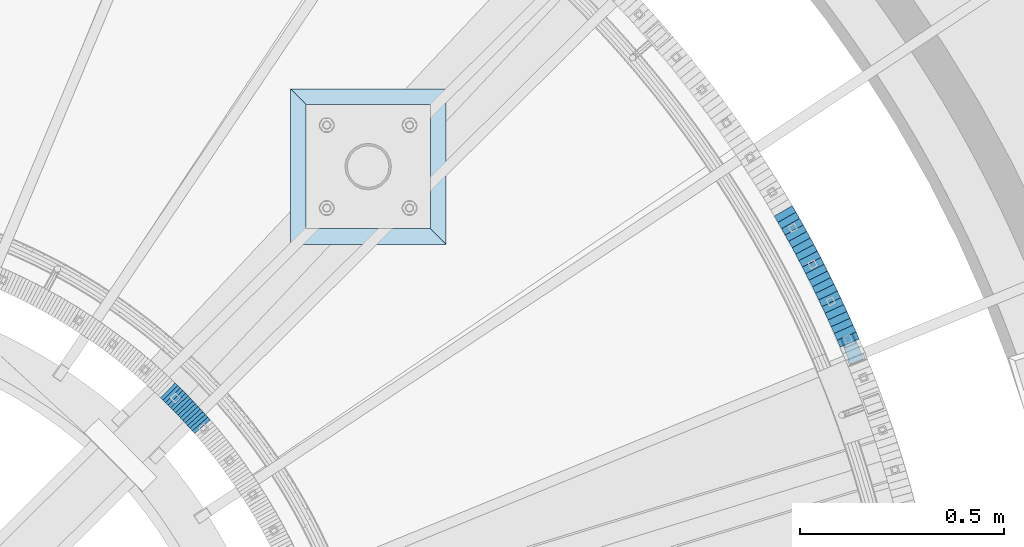
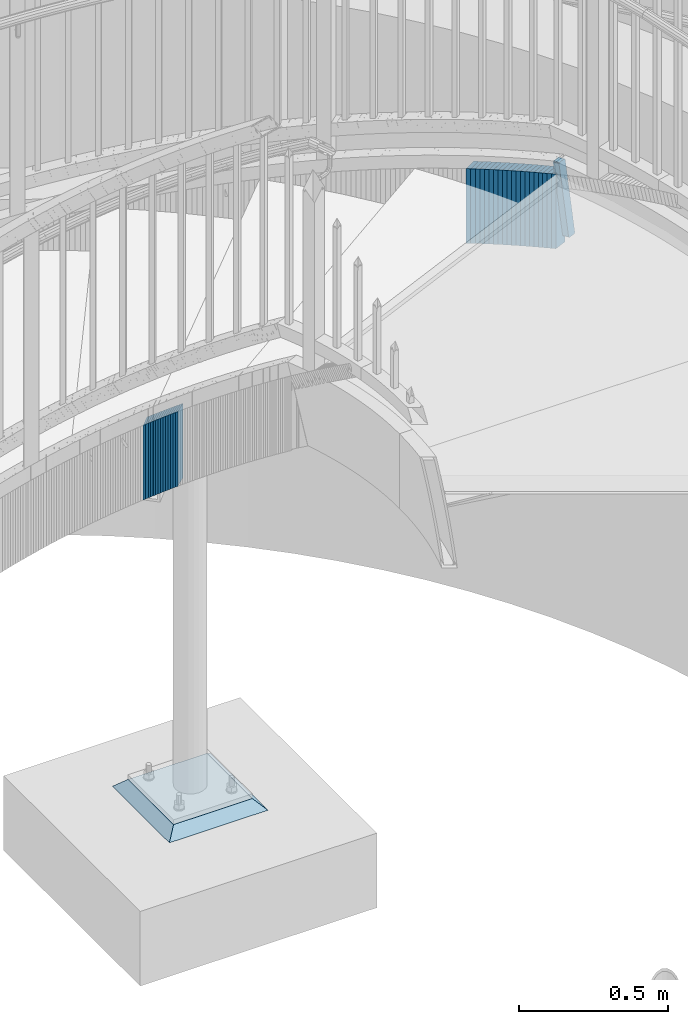
# One storey, part 911 of 975: 36 plates.
"""IFC2X3 building model written with IfcOpenShell, lengths in millimetres."""

from ifc_helpers import new_model, si_unit, frame, origin_with_axes, place, context, subcontext, project, spatial, faceted_brep, material, type_object, element, save


model = new_model("IFC2X3")

# Units and contexts
model_context = context("Model", 3, precision=1e-05, world=origin_with_axes())
body_context = subcontext(model_context, "Body", "Model", "MODEL_VIEW")
ifc_project = project(units=[si_unit("LENGTHUNIT", "METRE", prefix="MILLI"), si_unit("AREAUNIT", "SQUARE_METRE"), si_unit("VOLUMEUNIT", "CUBIC_METRE"), si_unit("MASSUNIT", "GRAM", prefix="KILO"), si_unit("TIMEUNIT", "SECOND"), si_unit("PLANEANGLEUNIT", "RADIAN"), si_unit("SOLIDANGLEUNIT", "STERADIAN"), si_unit("THERMODYNAMICTEMPERATUREUNIT", "DEGREE_CELSIUS"), si_unit("LUMINOUSINTENSITYUNIT", "LUMEN")], contexts=[model_context])

# Site, building, storey
site_placement = place(None, origin_with_axes())
site = spatial("IfcSite", under=ifc_project, at=site_placement, CompositionType="ELEMENT")
building_placement = place(site_placement, origin_with_axes())
building = spatial("IfcBuilding", under=site, at=building_placement, Name="Undefined", CompositionType="ELEMENT")
storey_placement = place(building_placement, origin_with_axes())
storey = spatial("IfcBuildingStorey", under=building, at=storey_placement, Name="Undefined", CompositionType="ELEMENT", Elevation=0.0)

# Plates
ifc_material_1 = material(Name="STEEL/A36")
plate_type_1 = type_object("IfcPlateType", PredefinedType="NOTDEFINED")
plate_1_placement = place(storey_placement, frame((37390.0475456913, 4538.09798117989, 2176.45959824117), z_axis=(0.0568676112012981, -0.132966091969578, -0.98948779334694), x_axis=(-0.920374035033144, -0.391039019014061, -0.000348203000012044)))
element("IfcPlate", 1, at=plate_1_placement, inside=storey, type_object=plate_type_1, material=ifc_material_1, Name="PLATE", context=body_context, shape_type="Brep", body=[
    faceted_brep([(0.0228958955340204, -12.699999999988, 6.3728136888293), (1.02632801964501, -12.6999999999025, 285.666801916679), (1.02632801963773, 12.700000000088, 285.666801916676), (0.0228958955340204, 12.7000000000007, 6.37281368882543), (1.51622114569182, -12.6999999999007, 288.089826975847), (1.51622114568454, 12.7000000000862, 288.089826975844), (2.89423209767847, -12.6999999999007, 290.142174784707), (2.89423209766392, 12.700000000088, 290.142174784703), (4.95151747122145, -12.6999999998989, 291.512803328148), (4.95151747121417, 12.7000000000917, 291.512803328144), (7.376286942359, -12.699999999897, 291.993988037131), (7.376286942359, 12.7000000000935, 291.993988037127), (29.6011096881266, -12.6999999998807, 291.993988037132), (29.6011096881193, 12.7000000001099, 291.993988037128), (32.036417817144, -12.6999999998789, 291.50843807308), (32.036417817144, 12.7000000001135, 291.508438073076), (34.0992964053003, -12.699999999877, 290.126042911988), (34.099296405293, 12.7000000001153, 290.126042911984), (35.4742712354564, -12.699999999877, 288.058211036017), (35.4742712354491, 12.7000000001153, 288.058211036012), (35.9510686101858, -12.6999999998734, 285.621174164258), (35.9510686101785, 12.7000000001135, 285.621174164253), (34.947628390335, -12.6999999999607, 6.32718593645666), (34.9476283903423, 12.7000000000298, 6.32718593645279), (34.4577352117849, -12.6999999999625, 3.90416093395709), (34.4577352117776, 12.700000000028, 3.90416093395277), (33.0797242477929, -12.6999999999625, 1.85181318753632), (33.0797242477856, 12.7000000000262, 1.85181318753177), (31.0224388969073, -12.6999999999662, 0.481184691480735), (31.0224388969073, 12.7000000000226, 0.481184691476415), (28.597669468305, -12.699999999968, 6.46878106635995e-11), (28.5976694682977, 12.7000000000226, 6.08224581810646e-11), (6.37285481827712, -12.699999999988, 1.55750967678614e-11), (6.37285481826984, 12.7000000000062, 1.10276232589968e-11), (3.93754673174408, -12.6999999999898, 0.485549946415972), (3.93754673174408, 12.7000000000044, 0.485549946412107), (1.87466816604865, -12.699999999988, 1.8679450599617), (1.87466816604865, 12.7000000000007, 1.86794505995761), (0.499693323406973, -12.6999999999898, 3.93577687344907), (0.499693323406973, 12.7000000000025, 3.93577687344407)], [[[0, 1, 2, 3]], [[1, 4, 5, 2]], [[4, 6, 7, 5]], [[6, 8, 9, 7]], [[8, 10, 11, 9]], [[10, 12, 13, 11]], [[12, 14, 15, 13]], [[14, 16, 17, 15]], [[16, 18, 19, 17]], [[18, 20, 21, 19]], [[20, 22, 23, 21]], [[22, 24, 25, 23]], [[24, 26, 27, 25]], [[26, 28, 29, 27]], [[28, 30, 31, 29]], [[30, 32, 33, 31]], [[32, 34, 35, 33]], [[34, 36, 37, 35]], [[36, 38, 39, 37]], [[38, 0, 3, 39]], [[5, 7, 9, 11, 13, 15, 17, 19, 21, 23, 25, 27, 29, 31, 33, 35, 37, 39, 3, 2]], [[38, 36, 34, 32, 30, 28, 26, 24, 22, 20, 18, 16, 14, 12, 10, 8, 6, 4, 1, 0]]]),
])
plate_type_2 = type_object("IfcPlateType", PredefinedType="NOTDEFINED")
plate_2_placement = place(storey_placement, frame((37369.2216824325, 4542.73662108243, 2127.79999999174), z_axis=(0.395909297944737, -0.918289620871817, 0.0), x_axis=(0.0, 0.0, -1.0)))
element("IfcPlate", 2, at=plate_2_placement, inside=storey, type_object=plate_type_2, material=ifc_material_1, Name="WALL", context=body_context, shape_type="Brep", body=[
    faceted_brep([(0.0, -25.3999999999724, -1.81898940354586e-11), (-5.80000019073486, -25.4000000000669, 18.1859836578205), (-5.80000019073486, 25.3999999999942, 18.1859836578369), (0.0, 25.3999999999869, 1.45519152283669e-11), (299.0, -25.4000000000669, 18.1859836578205), (299.0, 25.3999999999942, 18.1859836578369), (304.799987792969, -25.3999999999724, -1.81898940354586e-11), (304.799987792969, 25.3999999999869, 1.45519152283669e-11)], [[[0, 1, 2, 3]], [[1, 4, 5, 2]], [[4, 6, 7, 5]], [[6, 0, 3, 7]], [[5, 7, 3, 2]], [[6, 4, 1, 0]]]),
])
plate_3_placement = place(storey_placement, frame((37354.273054634, 4576.27457774003, 2116.09999999174), z_axis=(0.409214678154851, -0.912438133345282, 0.0), x_axis=(0.0, 0.0, -1.0)))
element("IfcPlate", 3, at=plate_3_placement, inside=storey, type_object=plate_type_2, material=ifc_material_1, Name="WALL", context=body_context, shape_type="Brep", body=[
    faceted_brep([(0.0, -25.3999999999724, -1.81898940354586e-11), (-5.80000019073486, -25.4000000000015, 18.0834178924524), (-5.80000019073486, 25.4000000000233, 18.0834178924579), (0.0, 25.3999999999869, 1.45519152283669e-11), (299.0, -25.4000000000015, 18.0834178924524), (299.0, 25.4000000000233, 18.0834178924579), (304.799987792969, -25.3999999999724, -1.81898940354586e-11), (304.799987792969, 25.3999999999869, 1.45519152283669e-11)], [[[0, 1, 2, 3]], [[1, 4, 5, 2]], [[4, 6, 7, 5]], [[6, 0, 3, 7]], [[5, 7, 3, 2]], [[6, 4, 1, 0]]]),
])
plate_4_placement = place(storey_placement, frame((37346.7204345728, 4592.89111969677, 2110.29999999174), z_axis=(0.413802944225842, -0.910366477496851, 0.0), x_axis=(0.0, 0.0, -1.0)))
element("IfcPlate", 4, at=plate_4_placement, inside=storey, type_object=plate_type_2, material=ifc_material_1, Name="WALL", context=body_context, shape_type="Brep", body=[
    faceted_brep([(0.0, -25.3999999999724, -1.81898940354586e-11), (-5.80000019073486, -25.3999999999796, 18.1245689392126), (-5.80000019073486, 25.3999999999651, 18.1245689391963), (0.0, 25.3999999999869, 1.45519152283669e-11), (299.0, -25.3999999999796, 18.1245689392126), (299.0, 25.3999999999651, 18.1245689391963), (304.799987792969, -25.3999999999724, -1.81898940354586e-11), (304.799987792969, 25.3999999999869, 1.45519152283669e-11)], [[[0, 1, 2, 3]], [[1, 4, 5, 2]], [[4, 6, 7, 5]], [[6, 0, 3, 7]], [[5, 7, 3, 2]], [[6, 4, 1, 0]]]),
])
plate_5_placement = place(storey_placement, frame((37339.0674721854, 4609.50686617453, 2104.49999999174), z_axis=(0.418359892189787, -0.908281344412044, 0.0), x_axis=(0.0, 0.0, -1.0)))
element("IfcPlate", 5, at=plate_5_placement, inside=storey, type_object=plate_type_2, material=ifc_material_1, Name="WALL", context=body_context, shape_type="Brep", body=[
    faceted_brep([(0.0, -25.3999999999724, -1.81898940354586e-11), (-5.80000019073486, -25.4000000000087, 18.1661777496374), (-5.80000019073486, 25.3999999999505, 18.1661777496083), (0.0, 25.3999999999869, 1.45519152283669e-11), (299.0, -25.4000000000087, 18.1661777496374), (299.0, 25.3999999999505, 18.1661777496083), (304.799987792969, -25.3999999999724, -1.81898940354586e-11), (304.799987792969, 25.3999999999869, 1.45519152283669e-11)], [[[0, 1, 2, 3]], [[1, 4, 5, 2]], [[4, 6, 7, 5]], [[6, 0, 3, 7]], [[5, 7, 3, 2]], [[6, 4, 1, 0]]]),
])
for number, where, z_axis, x_axis, name in (
    (6, (37331.2635302433, 4626.02968518606, 2098.69999999174), (0.427132294153765, -0.904189141325498, 0.0), (0.0, 0.0, -1.0), "WALL"),
    (7, (37323.5635302596, 4642.32968518814, 2092.89999999174), (0.427132294153765, -0.904189141325498, 0.0), (0.0, 0.0, -1.0), "WALL"),
):
    element("IfcPlate", number, at=place(storey_placement, frame(where, z_axis=z_axis, x_axis=x_axis)), inside=storey, type_object=plate_type_2, material=ifc_material_1, Name=name, context=body_context, shape_type="Brep", body=[
        faceted_brep([(0.0, -25.3999999999724, -1.81898940354586e-11), (-5.80000019073486, -25.4000000000306, 18.0272026061921), (-5.80000019073486, 25.4000000001324, 18.0272026062557), (0.0, 25.3999999999869, 1.45519152283669e-11), (299.0, -25.4000000000306, 18.0272026061921), (299.0, 25.4000000001324, 18.0272026062557), (304.799987792969, -25.3999999999724, -1.81898940354586e-11), (304.799987792969, 25.3999999999869, 1.45519152283669e-11)], [[[0, 1, 2, 3]], [[1, 4, 5, 2]], [[4, 6, 7, 5]], [[6, 0, 3, 7]], [[5, 7, 3, 2]], [[6, 4, 1, 0]]]),
    ])
plate_6_placement = place(storey_placement, frame((37315.5540722584, 4658.85843136293, 2087.09999999174), z_axis=(0.436138048991161, -0.89987977098176, 0.0), x_axis=(0.0, 0.0, -1.0)))
element("IfcPlate", 8, at=plate_6_placement, inside=storey, type_object=plate_type_2, material=ifc_material_1, Name="WALL", context=body_context, shape_type="Brep", body=[
    faceted_brep([(0.0, -25.3999999999724, -1.81898940354586e-11), (-5.80000019073486, -25.3999999998923, 18.1135311127164), (-5.80000019073486, 25.3999999999869, 18.1135311126727), (0.0, 25.3999999999869, 1.45519152283669e-11), (299.0, -25.3999999998923, 18.1135311127164), (299.0, 25.3999999999869, 18.1135311126727), (304.799987792969, -25.3999999999724, -1.81898940354586e-11), (304.799987792969, 25.3999999999869, 1.45519152283669e-11)], [[[0, 1, 2, 3]], [[1, 4, 5, 2]], [[4, 6, 7, 5]], [[6, 0, 3, 7]], [[5, 7, 3, 2]], [[6, 4, 1, 0]]]),
])
plate_7_placement = place(storey_placement, frame((37307.5999203446, 4675.06947365526, 2081.29999999174), z_axis=(0.440509792800287, -0.897747805593, 0.0), x_axis=(0.0, 0.0, -1.0)))
element("IfcPlate", 9, at=plate_7_placement, inside=storey, type_object=plate_type_2, material=ifc_material_1, Name="WALL", context=body_context, shape_type="Brep", body=[
    faceted_brep([(0.0, -25.3999999999724, -1.81898940354586e-11), (-5.80000019073486, -25.3999999998778, 17.9254016876821), (-5.80000019073486, 25.3999999999651, 17.9254016876057), (0.0, 25.3999999999869, 1.45519152283669e-11), (299.0, -25.3999999998778, 17.9254016876821), (299.0, 25.3999999999651, 17.9254016876057), (304.799987792969, -25.3999999999724, -1.81898940354586e-11), (304.799987792969, 25.3999999999869, 1.45519152283669e-11)], [[[0, 1, 2, 3]], [[1, 4, 5, 2]], [[4, 6, 7, 5]], [[6, 0, 3, 7]], [[5, 7, 3, 2]], [[6, 4, 1, 0]]]),
])
plate_8_placement = place(storey_placement, frame((37299.3873202256, 4691.3960884194, 2075.49999999174), z_axis=(0.449431633893284, -0.893314729787891, 0.0), x_axis=(0.0, 0.0, -1.0)))
element("IfcPlate", 10, at=plate_8_placement, inside=storey, type_object=plate_type_2, material=ifc_material_1, Name="WALL", context=body_context, shape_type="Brep", body=[
    faceted_brep([(0.0, -25.3999999999724, -1.81898940354586e-11), (-5.80000019073486, -25.3999999999141, 18.022764205969), (-5.80000019073486, 25.4000000000306, 18.0227642059417), (0.0, 25.3999999999869, 1.45519152283669e-11), (299.0, -25.3999999999141, 18.022764205969), (299.0, 25.4000000000306, 18.0227642059417), (304.799987792969, -25.3999999999724, -1.81898940354586e-11), (304.799987792969, 25.3999999999869, 1.45519152283669e-11)], [[[0, 1, 2, 3]], [[1, 4, 5, 2]], [[4, 6, 7, 5]], [[6, 0, 3, 7]], [[5, 7, 3, 2]], [[6, 4, 1, 0]]]),
])
plate_9_placement = place(storey_placement, frame((37291.2873202322, 4707.4960884193, 2069.79999999174), z_axis=(0.449431633893284, -0.893314729787891, 0.0), x_axis=(0.0, 0.0, -1.0)))
element("IfcPlate", 11, at=plate_9_placement, inside=storey, type_object=plate_type_2, material=ifc_material_1, Name="WALL", context=body_context, shape_type="Brep", body=[
    faceted_brep([(0.0, -25.3999999999724, -1.81898940354586e-11), (-5.69999980926514, -25.3999999999141, 18.0227642059708), (-5.69999980926514, 25.4000000000306, 18.0227642059454), (0.0, 25.3999999999869, 1.45519152283669e-11), (299.100006103516, -25.3999999999141, 18.0227642059708), (299.100006103516, 25.4000000000306, 18.0227642059454), (304.799987792969, -25.3999999999724, -1.81898940354586e-11), (304.799987792969, 25.3999999999869, 1.45519152283669e-11)], [[[0, 1, 2, 3]], [[1, 4, 5, 2]], [[4, 6, 7, 5]], [[6, 0, 3, 7]], [[5, 7, 3, 2]], [[6, 4, 1, 0]]]),
])
plate_10_placement = place(storey_placement, frame((37282.971822864, 4723.62282136612, 2063.99999999174), z_axis=(0.458358127885069, -0.888767588631412, 2.12838813240524e-11), x_axis=(0.0, 0.0, -1.0)))
element("IfcPlate", 12, at=plate_10_placement, inside=storey, type_object=plate_type_2, material=ifc_material_1, Name="WALL", context=body_context, shape_type="Brep", body=[
    faceted_brep([(0.0, -25.3999999999724, -1.81898940354586e-11), (-5.80000019073486, -25.4000000000378, 17.8932952880568), (-5.80000019073486, 25.4000000001179, 17.8932952881351), (0.0, 25.3999999999869, 1.45519152283669e-11), (299.0, -25.4000000000378, 17.8932952880568), (299.0, 25.4000000001179, 17.8932952881351), (304.799987792969, -25.3999999999724, -1.81898940354586e-11), (304.799987792969, 25.3999999999869, 1.45519152283669e-11)], [[[0, 1, 2, 3]], [[1, 4, 5, 2]], [[4, 6, 7, 5]], [[6, 0, 3, 7]], [[5, 7, 3, 2]], [[6, 4, 1, 0]]]),
])
plate_11_placement = place(storey_placement, frame((37274.6138556137, 4739.63454093765, 2058.29999999174), z_axis=(0.462756536214605, -0.886485413411107, 0.0), x_axis=(0.0, 0.0, -1.0)))
element("IfcPlate", 13, at=plate_11_placement, inside=storey, type_object=plate_type_2, material=ifc_material_1, Name="WALL", context=body_context, shape_type="Brep", body=[
    faceted_brep([(0.0, -25.3999999999724, -1.81898940354586e-11), (-5.69999980926514, -25.399999999885, 17.9387855530204), (-5.69999980926514, 25.3999999999651, 17.9387855529603), (0.0, 25.3999999999869, 1.45519152283669e-11), (299.100006103516, -25.399999999885, 17.9387855530204), (299.100006103516, 25.3999999999651, 17.9387855529603), (304.799987792969, -25.3999999999724, -1.81898940354586e-11), (304.799987792969, 25.3999999999869, 1.45519152283669e-11)], [[[0, 1, 2, 3]], [[1, 4, 5, 2]], [[4, 6, 7, 5]], [[6, 0, 3, 7]], [[5, 7, 3, 2]], [[6, 4, 1, 0]]]),
])
plate_12_placement = place(storey_placement, frame((37266.2833035019, 4755.49288394598, 2052.49999999174), z_axis=(0.465053504974094, -0.885282574950682, 0.0), x_axis=(0.0, 0.0, -1.0)))
element("IfcPlate", 14, at=plate_12_placement, inside=storey, type_object=plate_type_2, material=ifc_material_1, Name="WALL", context=body_context, shape_type="Brep", body=[
    faceted_brep([(0.0, -25.3999999999724, -1.81898940354586e-11), (-5.80000019073486, -25.3999999999869, 17.8549709320232), (-5.80000019073486, 25.3999999999432, 17.8549709319796), (0.0, 25.3999999999869, 1.45519152283669e-11), (299.0, -25.3999999999869, 17.8549709320232), (299.0, 25.3999999999432, 17.8549709319796), (304.799987792969, -25.3999999999724, -1.81898940354586e-11), (304.799987792969, 25.3999999999869, 1.45519152283669e-11)], [[[0, 1, 2, 3]], [[1, 4, 5, 2]], [[4, 6, 7, 5]], [[6, 0, 3, 7]], [[5, 7, 3, 2]], [[6, 4, 1, 0]]]),
])
plate_13_placement = place(storey_placement, frame((37257.6656363473, 4771.51421715978, 2046.79999999174), z_axis=(0.473767411038222, -0.88065001007105, 0.0), x_axis=(0.0, 0.0, -1.0)))
element("IfcPlate", 15, at=plate_13_placement, inside=storey, type_object=plate_type_2, material=ifc_material_1, Name="WALL", context=body_context, shape_type="Brep", body=[
    faceted_brep([(0.0, -25.3999999999724, -1.81898940354586e-11), (-5.69999980926514, -25.399999999885, 17.9387855530204), (-5.69999980926514, 25.3999999999651, 17.9387855529603), (0.0, 25.3999999999869, 1.45519152283669e-11), (299.100006103516, -25.399999999885, 17.9387855530204), (299.100006103516, 25.3999999999651, 17.9387855529603), (304.799987792969, -25.3999999999724, -1.81898940354586e-11), (304.799987792969, 25.3999999999869, 1.45519152283669e-11)], [[[0, 1, 2, 3]], [[1, 4, 5, 2]], [[4, 6, 7, 5]], [[6, 0, 3, 7]], [[5, 7, 3, 2]], [[6, 4, 1, 0]]]),
])
plate_14_placement = place(storey_placement, frame((37248.9739479182, 4787.38311521852, 2041.09999999174), z_axis=(0.480416940883703, -0.877040228787679, 0.0), x_axis=(0.0, 0.0, -1.0)))
element("IfcPlate", 16, at=plate_14_placement, inside=storey, type_object=plate_type_2, material=ifc_material_1, Name="WALL", context=body_context, shape_type="Brep", body=[
    faceted_brep([(0.0, -25.3999999999724, -1.81898940354586e-11), (-5.69999980926514, -25.3999999999578, 17.9047489166387), (-5.69999980926514, 25.3999999999069, 17.9047489165732), (0.0, 25.3999999999869, 1.45519152283669e-11), (299.100006103516, -25.3999999999578, 17.9047489166387), (299.100006103516, 25.3999999999069, 17.9047489165732), (304.799987792969, -25.3999999999724, -1.81898940354586e-11), (304.799987792969, 25.3999999999869, 1.45519152283669e-11)], [[[0, 1, 2, 3]], [[1, 4, 5, 2]], [[4, 6, 7, 5]], [[6, 0, 3, 7]], [[5, 7, 3, 2]], [[6, 4, 1, 0]]]),
])
plate_15_placement = place(storey_placement, frame((37240.3409573801, 4803.04314984637, 2035.39999999174), z_axis=(0.482780508932904, -0.875741388878295, 0.0), x_axis=(0.0, 0.0, -1.0)))
element("IfcPlate", 17, at=plate_15_placement, inside=storey, type_object=plate_type_2, material=ifc_material_1, Name="WALL", context=body_context, shape_type="Brep", body=[
    faceted_brep([(0.0, -25.3999999999724, -1.81898940354586e-11), (-5.69999980926514, -25.4000000001106, 17.8134784697704), (-5.69999980926514, 25.4000000000306, 17.8134784698614), (0.0, 25.3999999999869, 1.45519152283669e-11), (299.100006103516, -25.4000000001106, 17.8134784697704), (299.100006103516, 25.4000000000306, 17.8134784698614), (304.799987792969, -25.3999999999724, -1.81898940354586e-11), (304.799987792969, 25.3999999999869, 1.45519152283669e-11)], [[[0, 1, 2, 3]], [[1, 4, 5, 2]], [[4, 6, 7, 5]], [[6, 0, 3, 7]], [[5, 7, 3, 2]], [[6, 4, 1, 0]]]),
])
plate_16_placement = place(storey_placement, frame((37231.5465843385, 4818.71280148115, 2029.59999999174), z_axis=(0.489459707131159, -0.872025914233677, 0.0), x_axis=(0.0, 0.0, -1.0)))
element("IfcPlate", 18, at=plate_16_placement, inside=storey, type_object=plate_type_2, material=ifc_material_1, Name="WALL", context=body_context, shape_type="Brep", body=[
    faceted_brep([(0.0, -25.3999999999724, -1.81898940354586e-11), (-5.80000019073486, -25.400000000016, 17.7730140686072), (-5.80000019073486, 25.4000000000742, 17.7730140686326), (0.0, 25.3999999999869, 1.45519152283669e-11), (299.0, -25.400000000016, 17.7730140686072), (299.0, 25.4000000000742, 17.7730140686326), (304.799987792969, -25.3999999999724, -1.81898940354586e-11), (304.799987792969, 25.3999999999869, 1.45519152283669e-11)], [[[0, 1, 2, 3]], [[1, 4, 5, 2]], [[4, 6, 7, 5]], [[6, 0, 3, 7]], [[5, 7, 3, 2]], [[6, 4, 1, 0]]]),
])
plate_17_placement = place(storey_placement, frame((37222.6854948038, 4834.32101810368, 2023.89999999174), z_axis=(0.493720204004981, -0.869620814008773, 0.0), x_axis=(0.0, 0.0, -1.0)))
element("IfcPlate", 19, at=plate_17_placement, inside=storey, type_object=plate_type_2, material=ifc_material_1, Name="WALL", context=body_context, shape_type="Brep", body=[
    faceted_brep([(0.0, -25.3999999999724, -1.81898940354586e-11), (-5.69999980926514, -25.4000000000669, 17.8227386474155), (-5.69999980926514, 25.3999999999724, 17.8227386474609), (0.0, 25.3999999999869, 1.45519152283669e-11), (299.100006103516, -25.4000000000669, 17.8227386474155), (299.100006103516, 25.3999999999724, 17.8227386474609), (304.799987792969, -25.3999999999724, -1.81898940354586e-11), (304.799987792969, 25.3999999999869, 1.45519152283669e-11)], [[[0, 1, 2, 3]], [[1, 4, 5, 2]], [[4, 6, 7, 5]], [[6, 0, 3, 7]], [[5, 7, 3, 2]], [[6, 4, 1, 0]]]),
])
plate_18_placement = place(storey_placement, frame((37213.6887242365, 4849.88995499895, 2018.19999999174), z_axis=(0.500371262938832, -0.865810948894156, 0.0), x_axis=(0.0, 0.0, -1.0)))
element("IfcPlate", 20, at=plate_18_placement, inside=storey, type_object=plate_type_2, material=ifc_material_1, Name="WALL", context=body_context, shape_type="Brep", body=[
    faceted_brep([(0.0, -25.3999999999724, -1.81898940354586e-11), (-5.69999980926514, -25.4000000000306, 17.7867927551051), (-5.69999980926514, 25.4000000000888, 17.7867927551815), (0.0, 25.3999999999869, 1.45519152283669e-11), (299.100006103516, -25.4000000000306, 17.7867927551051), (299.100006103516, 25.4000000000888, 17.7867927551815), (304.799987792969, -25.3999999999724, -1.81898940354586e-11), (304.799987792969, 25.3999999999869, 1.45519152283669e-11)], [[[0, 1, 2, 3]], [[1, 4, 5, 2]], [[4, 6, 7, 5]], [[6, 0, 3, 7]], [[5, 7, 3, 2]], [[6, 4, 1, 0]]]),
])
plate_type_3 = type_object("IfcPlateType", PredefinedType="NOTDEFINED")
for number, where, z_axis, x_axis, name in (
    (21, (35782.8130838473, 4327.17119168392, 1841.10000000099), (0.660880367955666, -0.75049126527281, -6.81784513290041e-11), (0.0, 0.0, -1.0), "WALL"),
    (22, (35776.9130838502, 4333.87119168353, 1835.40000000099), (0.660880367955666, -0.75049126527281, -6.81784513290041e-11), (0.0, 0.0, -1.0), "WALL"),
):
    element("IfcPlate", number, at=place(storey_placement, frame(where, z_axis=z_axis, x_axis=x_axis)), inside=storey, type_object=plate_type_3, material=ifc_material_1, Name=name, context=body_context, shape_type="Brep", body=[
        faceted_brep([(0.0, -25.3999999999724, -1.81898940354586e-11), (-5.69999980926514, -25.3999999999141, 8.92748546604707), (-5.69999980926514, 25.3999999999505, 8.92748546598159), (0.0, 25.3999999999869, 1.45519152283669e-11), (299.100006103516, -25.3999999999141, 8.92748546604707), (299.100006103516, 25.3999999999505, 8.92748546598159), (304.799987792969, -25.3999999999724, -1.81898940354586e-11), (304.799987792969, 25.3999999999869, 1.45519152283669e-11)], [[[0, 1, 2, 3]], [[1, 4, 5, 2]], [[4, 6, 7, 5]], [[6, 0, 3, 7]], [[5, 7, 3, 2]], [[6, 4, 1, 0]]]),
    ])
plate_19_placement = place(storey_placement, frame((35771.0538206242, 4340.41271003745, 1829.70000000097), z_axis=(0.667119803196771, -0.744950446796766, -1.78824848262593e-10), x_axis=(0.0, 0.0, -1.0)))
element("IfcPlate", 23, at=plate_19_placement, inside=storey, type_object=plate_type_3, material=ifc_material_1, Name="WALL", context=body_context, shape_type="Brep", body=[
    faceted_brep([(0.0, -25.3999999999724, -1.81898940354586e-11), (-5.69999980926514, -25.3999999999724, 8.9872131347729), (-5.69999980926514, 25.3999999999833, 8.98721313475835), (0.0, 25.3999999999869, 1.45519152283669e-11), (299.100006103516, -25.3999999999724, 8.9872131347729), (299.100006103516, 25.3999999999833, 8.98721313475835), (304.799987792969, -25.3999999999724, -1.81898940354586e-11), (304.799987792969, 25.3999999999869, 1.45519152283669e-11)], [[[0, 1, 2, 3]], [[1, 4, 5, 2]], [[4, 6, 7, 5]], [[6, 0, 3, 7]], [[5, 7, 3, 2]], [[6, 4, 1, 0]]]),
])
plate_20_placement = place(storey_placement, frame((35765.1810841107, 4346.87166406094, 1823.90000000096), z_axis=(0.672672794095991, -0.739940073305327, 8.58585735841189e-11), x_axis=(0.0, 0.0, -1.0)))
element("IfcPlate", 24, at=plate_20_placement, inside=storey, type_object=plate_type_3, material=ifc_material_1, Name="WALL", context=body_context, shape_type="Brep", body=[
    faceted_brep([(0.0, -25.3999999999724, -1.81898940354586e-11), (-5.80000019073486, -25.3999999999724, 8.9196414947728), (-5.80000019073486, 25.4000000000342, 8.91964149478736), (0.0, 25.3999999999869, 1.45519152283669e-11), (299.0, -25.3999999999724, 8.9196414947728), (299.0, 25.4000000000342, 8.91964149478736), (304.799987792969, -25.3999999999724, -1.81898940354586e-11), (304.799987792969, 25.3999999999869, 1.45519152283669e-11)], [[[0, 1, 2, 3]], [[1, 4, 5, 2]], [[4, 6, 7, 5]], [[6, 0, 3, 7]], [[5, 7, 3, 2]], [[6, 4, 1, 0]]]),
])
plate_21_placement = place(storey_placement, frame((35759.3542053965, 4353.0759722529, 1818.20000000095), z_axis=(0.684314204029273, -0.729187266868932, -7.10006133886054e-11), x_axis=(0.0, 0.0, -1.0)))
element("IfcPlate", 25, at=plate_21_placement, inside=storey, type_object=plate_type_3, material=ifc_material_1, Name="WALL", context=body_context, shape_type="Brep", body=[
    faceted_brep([(0.0, -25.3999999999724, -1.81898940354586e-11), (-5.69999980926514, -25.400000000096, 8.9140338897214), (-5.69999980926514, 25.4000000000524, 8.91403388979779), (0.0, 25.3999999999869, 1.45519152283669e-11), (299.100006103516, -25.400000000096, 8.9140338897214), (299.100006103516, 25.4000000000524, 8.91403388979779), (304.799987792969, -25.3999999999724, -1.81898940354586e-11), (304.799987792969, 25.3999999999869, 1.45519152283669e-11)], [[[0, 1, 2, 3]], [[1, 4, 5, 2]], [[4, 6, 7, 5]], [[6, 0, 3, 7]], [[5, 7, 3, 2]], [[6, 4, 1, 0]]]),
])
plate_22_placement = place(storey_placement, frame((35753.1223935952, 4359.81750346302, 1812.50000000094), z_axis=(0.678742108762795, -0.734376708367194, 2.68552412308054e-10), x_axis=(0.0, 0.0, -1.0)))
element("IfcPlate", 26, at=plate_22_placement, inside=storey, type_object=plate_type_3, material=ifc_material_1, Name="WALL", context=body_context, shape_type="Brep", body=[
    faceted_brep([(0.0, -25.3999999999724, -1.81898940354586e-11), (-5.69999980926514, -25.3999999999724, 8.9872131347729), (-5.69999980926514, 25.3999999999833, 8.98721313475835), (0.0, 25.3999999999869, 1.45519152283669e-11), (299.100006103516, -25.3999999999724, 8.9872131347729), (299.100006103516, 25.3999999999833, 8.98721313475835), (304.799987792969, -25.3999999999724, -1.81898940354586e-11), (304.799987792969, 25.3999999999869, 1.45519152283669e-11)], [[[0, 1, 2, 3]], [[1, 4, 5, 2]], [[4, 6, 7, 5]], [[6, 0, 3, 7]], [[5, 7, 3, 2]], [[6, 4, 1, 0]]]),
])
plate_23_placement = place(storey_placement, frame((35747.1542054065, 4366.17597225286, 1806.70000000093), z_axis=(0.684314204029273, -0.729187266868932, -7.10006133886054e-11), x_axis=(0.0, 0.0, -1.0)))
element("IfcPlate", 27, at=plate_23_placement, inside=storey, type_object=plate_type_3, material=ifc_material_1, Name="WALL", context=body_context, shape_type="Brep", body=[
    faceted_brep([(0.0, -25.3999999999724, -1.81898940354586e-11), (-5.80000019073486, -25.399999999976, 8.91066741944087), (-5.80000019073486, 25.4000000000051, 8.91066741945178), (0.0, 25.3999999999869, 1.45519152283669e-11), (299.0, -25.399999999976, 8.91066741944087), (299.0, 25.4000000000051, 8.91066741945178), (304.799987792969, -25.3999999999724, -1.81898940354586e-11), (304.799987792969, 25.3999999999869, 1.45519152283669e-11)], [[[0, 1, 2, 3]], [[1, 4, 5, 2]], [[4, 6, 7, 5]], [[6, 0, 3, 7]], [[5, 7, 3, 2]], [[6, 4, 1, 0]]]),
])
plate_24_placement = place(storey_placement, frame((35741.232260332, 4372.28435455147, 1801.00000000093), z_axis=(0.695795215511426, -0.718240223094898, 2.71390035777586e-10), x_axis=(0.0, 0.0, -1.0)))
element("IfcPlate", 28, at=plate_24_placement, inside=storey, type_object=plate_type_3, material=ifc_material_1, Name="WALL", context=body_context, shape_type="Brep", body=[
    faceted_brep([(0.0, -25.3999999999724, -1.81898940354586e-11), (-5.69999980926514, -25.400000000096, 8.9140338897214), (-5.69999980926514, 25.4000000000524, 8.91403388979779), (0.0, 25.3999999999869, 1.45519152283669e-11), (299.100006103516, -25.400000000096, 8.9140338897214), (299.100006103516, 25.4000000000524, 8.91403388979779), (304.799987792969, -25.3999999999724, -1.81898940354586e-11), (304.799987792969, 25.3999999999869, 1.45519152283669e-11)], [[[0, 1, 2, 3]], [[1, 4, 5, 2]], [[4, 6, 7, 5]], [[6, 0, 3, 7]], [[5, 7, 3, 2]], [[6, 4, 1, 0]]]),
])
plate_25_placement = place(storey_placement, frame((35734.8959128927, 4378.92619543559, 1795.20000000092), z_axis=(0.690210929024432, -0.723608232025611, 0.0), x_axis=(0.0, 0.0, -1.0)))
element("IfcPlate", 29, at=plate_25_placement, inside=storey, type_object=plate_type_3, material=ifc_material_1, Name="WALL", context=body_context, shape_type="Brep", body=[
    faceted_brep([(0.0, -25.3999999999724, -1.81898940354586e-11), (-5.80000019073486, -25.3999999999542, 8.98276138308574), (-5.80000019073486, 25.3999999999469, 8.98276138302026), (0.0, 25.3999999999869, 1.45519152283669e-11), (299.0, -25.3999999999542, 8.98276138308574), (299.0, 25.3999999999469, 8.98276138302026), (304.799987792969, -25.3999999999724, -1.81898940354586e-11), (304.799987792969, 25.3999999999869, 1.45519152283669e-11)], [[[0, 1, 2, 3]], [[1, 4, 5, 2]], [[4, 6, 7, 5]], [[6, 0, 3, 7]], [[5, 7, 3, 2]], [[6, 4, 1, 0]]]),
])
plate_26_placement = place(storey_placement, frame((35729.0150497385, 4384.79704079021, 1789.50000000091), z_axis=(0.707106781186513, -0.707106781186582, 3.1377567211166e-14), x_axis=(0.0, 0.0, -1.0)))
element("IfcPlate", 30, at=plate_26_placement, inside=storey, type_object=plate_type_3, material=ifc_material_1, Name="WALL", context=body_context, shape_type="Brep", body=[
    faceted_brep([(0.0, -25.3999999999724, -1.81898940354586e-11), (-5.69999980926514, -25.400000000096, 8.9140338897214), (-5.69999980926514, 25.4000000000524, 8.91403388979779), (0.0, 25.3999999999869, 1.45519152283669e-11), (299.100006103516, -25.400000000096, 8.9140338897214), (299.100006103516, 25.4000000000524, 8.91403388979779), (304.799987792969, -25.3999999999724, -1.81898940354586e-11), (304.799987792969, 25.3999999999869, 1.45519152283669e-11)], [[[0, 1, 2, 3]], [[1, 4, 5, 2]], [[4, 6, 7, 5]], [[6, 0, 3, 7]], [[5, 7, 3, 2]], [[6, 4, 1, 0]]]),
])
plate_27_placement = place(storey_placement, frame((35722.5741895335, 4391.3390145051, 1783.70000000091), z_axis=(0.701517264451547, -0.712652459250944, 3.59814748662756e-10), x_axis=(0.0, 0.0, -1.0)))
element("IfcPlate", 31, at=plate_27_placement, inside=storey, type_object=plate_type_3, material=ifc_material_1, Name="WALL", context=body_context, shape_type="Brep", body=[
    faceted_brep([(0.0, -25.3999999999724, -1.81898940354586e-11), (-5.80000019073486, -25.3999999999542, 8.98276138308574), (-5.80000019073486, 25.3999999999469, 8.98276138302026), (0.0, 25.3999999999869, 1.45519152283669e-11), (299.0, -25.3999999999542, 8.98276138308574), (299.0, 25.3999999999469, 8.98276138302026), (304.799987792969, -25.3999999999724, -1.81898940354586e-11), (304.799987792969, 25.3999999999869, 1.45519152283669e-11)], [[[0, 1, 2, 3]], [[1, 4, 5, 2]], [[4, 6, 7, 5]], [[6, 0, 3, 7]], [[5, 7, 3, 2]], [[6, 4, 1, 0]]]),
])
for number, where, z_axis, x_axis, name in (
    (32, (35716.4570234677, 4397.35618057758, 1778.0000000009), (0.712652459251016, -0.701517264451473, -3.59879322786582e-10), (0.0, 0.0, -1.0), "WALL"),
    (33, (35710.0570234744, 4403.65618057784, 1772.3000000009), (0.712652459251016, -0.701517264451473, -3.59879322786582e-10), (0.0, 0.0, -1.0), "WALL"),
):
    element("IfcPlate", number, at=place(storey_placement, frame(where, z_axis=z_axis, x_axis=x_axis)), inside=storey, type_object=plate_type_3, material=ifc_material_1, Name=name, context=body_context, shape_type="Brep", body=[
        faceted_brep([(0.0, -25.3999999999724, -1.81898940354586e-11), (-5.69999980926514, -25.3999999999833, 8.98053455353147), (-5.69999980926514, 25.3999999999396, 8.98053455348781), (0.0, 25.3999999999869, 1.45519152283669e-11), (299.100006103516, -25.3999999999833, 8.98053455353147), (299.100006103516, 25.3999999999396, 8.98053455348781), (304.799987792969, -25.3999999999724, -1.81898940354586e-11), (304.799987792969, 25.3999999999869, 1.45519152283669e-11)], [[[0, 1, 2, 3]], [[1, 4, 5, 2]], [[4, 6, 7, 5]], [[6, 0, 3, 7]], [[5, 7, 3, 2]], [[6, 4, 1, 0]]]),
    ])
plate_28_placement = place(storey_placement, frame((35703.8023635235, 4409.71425137386, 1766.5000000009), z_axis=(0.718240222846302, -0.69579521576804, -3.81628524337429e-11), x_axis=(0.0, 0.0, -1.0)))
element("IfcPlate", 34, at=plate_28_placement, inside=storey, type_object=plate_type_3, material=ifc_material_1, Name="WALL", context=body_context, shape_type="Brep", body=[
    faceted_brep([(0.0, -25.3999999999724, -1.81898940354586e-11), (-5.80000019073486, -25.399999999976, 8.91066741944087), (-5.80000019073486, 25.4000000000051, 8.91066741945178), (0.0, 25.3999999999869, 1.45519152283669e-11), (299.0, -25.399999999976, 8.91066741944087), (299.0, 25.4000000000051, 8.91066741945178), (304.799987792969, -25.3999999999724, -1.81898940354586e-11), (304.799987792969, 25.3999999999869, 1.45519152283669e-11)], [[[0, 1, 2, 3]], [[1, 4, 5, 2]], [[4, 6, 7, 5]], [[6, 0, 3, 7]], [[5, 7, 3, 2]], [[6, 4, 1, 0]]]),
])
plate_type_4 = type_object("IfcPlateType", PredefinedType="NOTDEFINED")
plate_29_placement = place(storey_placement, frame((37361.7193935434, 4559.67063146607, 2121.89999999174), z_axis=(0.40512230518509, -0.91426249941771, 0.0), x_axis=(0.0, 0.0, -1.0)))
element("IfcPlate", 35, at=plate_29_placement, inside=storey, type_object=plate_type_4, material=ifc_material_1, Name="WALL", context=body_context, shape_type="Brep", body=[
    faceted_brep([(0.0, -25.3999999999724, -1.81898940354586e-11), (-5.90000009536743, -25.4000000000233, 18.2660884856905), (-5.90000009536743, 25.4000000000742, 18.266088485756), (0.0, 25.3999999999869, 1.45519152283669e-11), (298.899993896484, -25.4000000000233, 18.2660884856905), (298.899993896484, 25.4000000000742, 18.266088485756), (304.799987792969, -25.3999999999724, -1.81898940354586e-11), (304.799987792969, 25.3999999999869, 1.45519152283669e-11)], [[[0, 1, 2, 3]], [[1, 4, 5, 2]], [[4, 6, 7, 5]], [[6, 0, 3, 7]], [[5, 7, 3, 2]], [[6, 4, 1, 0]]]),
])
ifc_material_2 = material(Name="CONCRETE/GROUT")
plate_type_5 = type_object("IfcPlateType", PredefinedType="NOTDEFINED")
plate_30_placement = place(storey_placement, frame((36385.8595913399, 4768.19262568484, -260.349999999999), z_axis=(-0.999999999999998, 6.90000001668524e-08, 0.0), x_axis=(0.0, 1.0, 0.0)))
element("IfcPlate", 36, at=plate_30_placement, inside=storey, type_object=plate_type_5, material=ifc_material_2, Name="GROUT", context=body_context, shape_type="Brep", body=[
    faceted_brep([(38.1000000096292, -19.05, 342.899999985777), (0.0, 19.05, 381.0), (2.63382389675826e-07, 19.0500000000138, 0.0), (38.1000000092372, -19.05, 38.1000000116328), (342.899999988684, -19.05, 38.1000000120257), (381.0, 19.05, 0.0), (381.0, 19.05, 381.0), (342.899999989076, -19.05, 342.89999998617)], [[[0, 1, 2, 3]], [[4, 5, 6, 7]], [[4, 7, 0, 3]], [[5, 4, 3, 2]], [[6, 5, 2, 1]], [[7, 6, 1, 0]]]),
])

save(model, "model.ifc")
